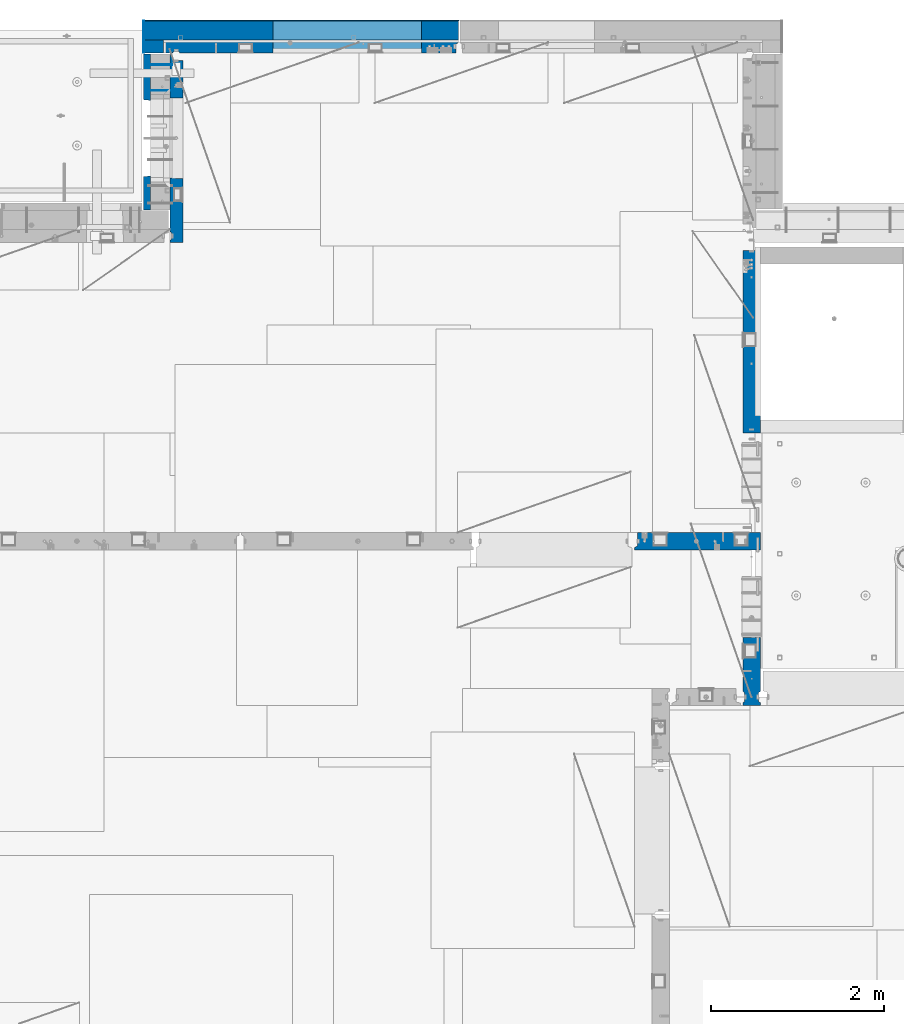
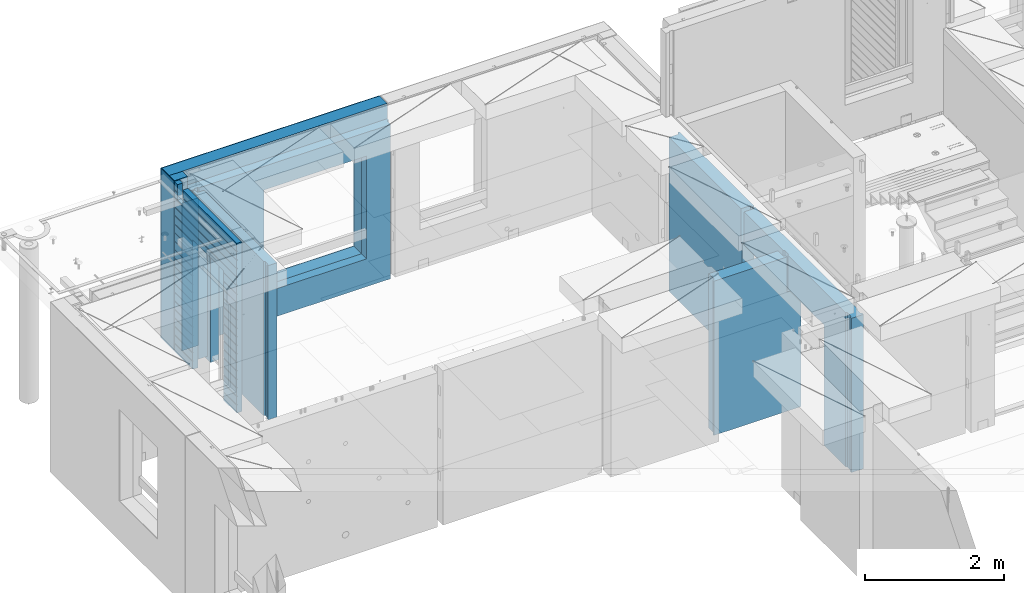
# One storey, part 236 of 349: 12 walls, 5 elements without a shape of their own.
"""IFC2X3 building model written with IfcOpenShell, lengths in millimetres."""

import ifcopenshell
import ifcopenshell.guid

model = None  # the IFC model being written
_history = None  # IfcOwnerHistory: only IFC2X3 demands one
_inside = {}  # id of a spatial element -> (the spatial element, [elements in it])
_under = {}  # id of a project, library or spatial element -> (it, [spatial elements below it])
_declared = {}  # id of a project -> (the project, [libraries it declares])
_typed = {}  # id of a type object -> (the type object, [elements of that type])
_made_of = {}  # id of a material, layer set ... -> (it, [elements and type objects made of it])


def new_model(schema):
    """Start an empty IFC model of exactly this schema.

    Asked for "IFC4X3", IfcOpenShell would pick the latest addendum, in which some entities
    have other attributes; the version numbers below select the first issue.
    IFC2X3 requires an IfcOwnerHistory on every rooted entity: one is made here for all.
    """
    global model, _history
    if schema == "IFC4X3":
        model = ifcopenshell.file(schema_version=(4, 3, 0, 0))
    else:
        model = ifcopenshell.file(schema=schema)
    _inside.clear()
    _under.clear()
    _declared.clear()
    _typed.clear()
    _made_of.clear()
    _history = None
    if model.schema == "IFC2X3":
        org = make("IfcOrganization", Name="unknown")
        user = make(
            "IfcPersonAndOrganization",
            ThePerson=make("IfcPerson", FamilyName="unknown"),
            TheOrganization=org,
        )
        app = make(
            "IfcApplication",
            ApplicationDeveloper=org,
            Version="unknown",
            ApplicationFullName="unknown",
            ApplicationIdentifier="unknown",
        )
        _history = make(
            "IfcOwnerHistory",
            OwningUser=user,
            OwningApplication=app,
            ChangeAction="ADDED",
            CreationDate=0,
        )
    return model


def make(cls, **values):
    """One entity of the class cls with the attributes given. An attribute that is None is left unset."""
    return model.create_entity(
        cls, **{name: value for name, value in values.items() if value is not None}
    )


def rooted(cls, **values):
    """An entity with a GlobalId (a new one), such as an element, a storey or a relation."""
    return make(cls, GlobalId=ifcopenshell.guid.new(), OwnerHistory=_history, **values)


def si_unit(unit_type, name, prefix=None):
    """IfcSIUnit, for example si_unit("LENGTHUNIT", "METRE", prefix="MILLI")."""
    return make("IfcSIUnit", UnitType=unit_type, Prefix=prefix, Name=name)


def assignment(units):
    """IfcUnitAssignment: the units of a project."""
    return None if units is None else make("IfcUnitAssignment", Units=units)


def point(xyz):
    """IfcCartesianPoint."""
    return None if xyz is None else make("IfcCartesianPoint", Coordinates=xyz)


def direction(xyz):
    """IfcDirection."""
    return None if xyz is None else make("IfcDirection", DirectionRatios=xyz)


def frame(location, z_axis=None, x_axis=None):
    """IfcAxis2Placement3D, a coordinate frame: its origin and axes. An axis left out is left unset."""
    return make(
        "IfcAxis2Placement3D",
        Location=point(location),
        Axis=direction(z_axis),
        RefDirection=direction(x_axis),
    )


def origin_with_axes():
    """The frame at (0, 0, 0) with the z axis (0, 0, 1) and the x axis (1, 0, 0) written out."""
    return frame((0.0, 0.0, 0.0), z_axis=(0.0, 0.0, 1.0), x_axis=(1.0, 0.0, 0.0))


def place(relative_to, where):
    """IfcLocalPlacement: puts the frame where relative to a parent placement (None: the world)."""
    return make(
        "IfcLocalPlacement", PlacementRelTo=relative_to, RelativePlacement=where
    )


def context(
    kind, dimensions, precision=None, world=None, true_north=None, identifier=None
):
    """IfcGeometricRepresentationContext, for example the 3D "Model" context."""
    return make(
        "IfcGeometricRepresentationContext",
        ContextIdentifier=identifier,
        ContextType=kind,
        CoordinateSpaceDimension=dimensions,
        Precision=precision,
        WorldCoordinateSystem=world,
        TrueNorth=true_north,
    )


def subcontext(parent, identifier, kind, view, scale=None):
    """IfcGeometricRepresentationSubContext, for example "Body" below "Model"."""
    return make(
        "IfcGeometricRepresentationSubContext",
        ContextIdentifier=identifier,
        ContextType=kind,
        ParentContext=parent,
        TargetScale=scale,
        TargetView=view,
    )


def project(units=None, contexts=None):
    """IfcProject with its units and contexts."""
    return rooted(
        "IfcProject",
        Name="project",
        RepresentationContexts=contexts,
        UnitsInContext=assignment(units),
    )


def spatial(cls, under=None, at=None, **own):
    """A site, building, storey or space (cls), placed at a placement, below another one or the project."""
    s = rooted(cls, ObjectPlacement=at, **own)
    if under is not None:
        _under.setdefault(under.id(), (under, []))[1].append(s)
    return s


def faces_of(points, faces, orient=None, outer=None):
    """IfcFace entities. A face is a list of loops; a loop is a list of indices into points, from 0.

    orient and outer hold one flag for each loop. By default every Orientation is true, the
    first loop of a face is its IfcFaceOuterBound and the others are IfcFaceBound.
    """
    made = []
    for i, loops in enumerate(faces):
        bounds = []
        for j, loop in enumerate(loops):
            is_outer = j == 0 if outer is None else outer[i][j]
            bounds.append(
                make(
                    "IfcFaceOuterBound" if is_outer else "IfcFaceBound",
                    Bound=make("IfcPolyLoop", Polygon=[points[k] for k in loop]),
                    Orientation=True if orient is None else orient[i][j],
                )
            )
        made.append(make("IfcFace", Bounds=bounds))
    return made


def faceted_brep(points, faces, orient=None, outer=None, voids=None):
    """IfcFacetedBrep: a solid bounded by flat faces; with voids (closed shells), ...WithVoids."""
    shared = [point(p) for p in points]
    hull = make("IfcClosedShell", CfsFaces=faces_of(shared, faces, orient, outer))
    if voids is None:
        return make("IfcFacetedBrep", Outer=hull)
    return make(
        "IfcFacetedBrepWithVoids",
        Outer=hull,
        Voids=[
            make(cls, CfsFaces=faces_of(shared, fs, o, b)) for cls, fs, o, b in voids
        ],
    )


def shape(context_of_items, identifier, shape_type, items):
    """IfcShapeRepresentation: the items that make up one representation, for example the "Body"."""
    return make(
        "IfcShapeRepresentation",
        ContextOfItems=context_of_items,
        RepresentationIdentifier=identifier,
        RepresentationType=shape_type,
        Items=items,
    )


def material(Name=None, Category=None):
    """IfcMaterial."""
    return make("IfcMaterial", Name=Name, Category=Category)


def made_of(thing, what):
    """Note that an element or type object is made of a material, layer set ...; save() writes the relation."""
    if what is not None:
        _made_of.setdefault(what.id(), (what, []))[1].append(thing)
    return thing


def type_object(cls, material=None, **own):
    """A type object (cls), such as IfcWallType, which elements share."""
    return made_of(rooted(cls, **own), material)


def element(
    cls,
    number,
    at=None,
    inside=None,
    cuts=None,
    type_object=None,
    material=None,
    context=None,
    identifier="Body",
    shape_type=None,
    held_by="IfcProductDefinitionShape",
    body=None,
    shapes=None,
    **own,
):
    """One element of the class cls, such as IfcWall. Its Tag is "e" and its number.

    at: its placement. inside: the storey or other place that contains it. cuts: it is an
    opening in that element (IfcRelVoidsElement). A single representation is given by context,
    identifier, shape_type and body (its items); several are given by shapes. held_by: the class
    of the entity that holds the representations. save() writes the other relations.
    """
    e = rooted(cls, Tag="e%d" % number, ObjectPlacement=at, **own)
    if body is not None:
        shapes = [shape(context, identifier, shape_type, body)]
    if shapes is not None:
        e.Representation = make(held_by, Representations=shapes)
    if inside is not None:
        _inside.setdefault(inside.id(), (inside, []))[1].append(e)
    if cuts is not None:
        rooted(
            "IfcRelVoidsElement", RelatingBuildingElement=cuts, RelatedOpeningElement=e
        )
    if type_object is not None:
        _typed.setdefault(type_object.id(), (type_object, []))[1].append(e)
    return made_of(e, material)


def aggregate(whole, parts):
    """IfcRelAggregates: a whole, such as a stair, and the parts it consists of."""
    return rooted("IfcRelAggregates", RelatingObject=whole, RelatedObjects=parts)


def save(model, path):
    """Write the relations noted so far, then the file.

    IfcRelAggregates (storeys below a building ...), IfcRelContainedInSpatialStructure (elements
    in a storey), IfcRelDefinesByType, IfcRelAssociatesMaterial and IfcRelDeclares: one each for
    every whole, place, type object, material and project.
    """
    for whole, parts in _under.values():
        aggregate(whole, parts)
    for where, things in _inside.values():
        rooted(
            "IfcRelContainedInSpatialStructure",
            RelatedElements=things,
            RelatingStructure=where,
        )
    for kind, things in _typed.values():
        rooted("IfcRelDefinesByType", RelatedObjects=things, RelatingType=kind)
    for what, things in _made_of.values():
        rooted("IfcRelAssociatesMaterial", RelatedObjects=things, RelatingMaterial=what)
    for by, libraries in _declared.values():
        rooted("IfcRelDeclares", RelatingContext=by, RelatedDefinitions=libraries)
    model.write(path)


model = new_model("IFC2X3")

# Units and contexts
model_context = context("Model", 3, precision=1e-05, world=origin_with_axes())
body_context = subcontext(model_context, "Body", "Model", "MODEL_VIEW")
ifc_project = project(units=[si_unit("LENGTHUNIT", "METRE", prefix="MILLI"), si_unit("AREAUNIT", "SQUARE_METRE"), si_unit("VOLUMEUNIT", "CUBIC_METRE"), si_unit("MASSUNIT", "GRAM", prefix="KILO"), si_unit("TIMEUNIT", "SECOND"), si_unit("PLANEANGLEUNIT", "RADIAN"), si_unit("SOLIDANGLEUNIT", "STERADIAN"), si_unit("THERMODYNAMICTEMPERATUREUNIT", "DEGREE_CELSIUS"), si_unit("LUMINOUSINTENSITYUNIT", "LUMEN")], contexts=[model_context])

# Site, building, storey
site_placement = place(None, origin_with_axes())
site = spatial("IfcSite", under=ifc_project, at=site_placement, CompositionType="ELEMENT")
building_placement = place(site_placement, origin_with_axes())
building = spatial("IfcBuilding", under=site, at=building_placement, CompositionType="ELEMENT")
storey_placement = place(building_placement, origin_with_axes())
storey = spatial("IfcBuildingStorey", under=building, at=storey_placement, Name="4", CompositionType="ELEMENT", Elevation=0.0)

# Assembly, walls
assembly_1_placement = place(storey_placement, origin_with_axes())
assembly_1 = element("IfcElementAssembly", 1, at=assembly_1_placement, inside=storey, AssemblyPlace="NOTDEFINED", PredefinedType="REINFORCEMENT_UNIT")
ifc_material_1 = material(Name="Undefined")
wall_type_1 = type_object("IfcWallType", PredefinedType="NOTDEFINED")
wall_1_placement = place(assembly_1_placement, frame((11020.0, 22485.0002441406, 92115.0), z_axis=(0.0, 0.0, 1.0), x_axis=(-1.0, 3.00000001838171e-08, 0.0)))
wall_1 = element("IfcWall", 2, at=wall_1_placement, type_object=wall_type_1, material=ifc_material_1, Name="(PD)", context=body_context, shape_type="Brep", body=[
    faceted_brep([(0.0, 5.0, -1300.0), (0.0, 5.0, 1300.0), (280.0, 5.0, 1300.0), (280.0, 5.0, -1300.0), (0.0, -5.0, 1300.0), (280.0, -5.0, 1300.0), (0.0, -5.0, -1300.0), (280.0, -5.0, -1300.0)], [[[0, 1, 2, 3]], [[1, 4, 5, 2]], [[4, 6, 7, 5]], [[6, 0, 3, 7]], [[5, 7, 3, 2]], [[6, 4, 1, 0]]]),
])
wall_2_placement = place(assembly_1_placement, frame((11020.0, 22185.0002441406, 92115.0), z_axis=(0.0, 0.0, 1.0), x_axis=(-1.0, 3.00000001838171e-08, 0.0)))
wall_2 = element("IfcWall", 3, at=wall_2_placement, type_object=wall_type_1, material=ifc_material_1, Name="(PD)", context=body_context, shape_type="Brep", body=[
    faceted_brep([(0.0, 5.0, -1300.0), (0.0, 5.0, 1300.0), (280.0, 5.0, 1300.0), (280.0, 5.0, -1300.0), (0.0, -5.0, 1300.0), (280.0, -5.0, 1300.0), (0.0, -5.0, -1300.0), (280.0, -5.0, -1300.0)], [[[0, 1, 2, 3]], [[1, 4, 5, 2]], [[4, 6, 7, 5]], [[6, 0, 3, 7]], [[5, 7, 3, 2]], [[6, 4, 1, 0]]]),
])

# Assembly, wall
assembly_2_placement = place(storey_placement, origin_with_axes())
assembly_2 = element("IfcElementAssembly", 4, at=assembly_2_placement, inside=storey, AssemblyPlace="NOTDEFINED", PredefinedType="REINFORCEMENT_UNIT")
ifc_material_2 = material(Name="CONCRETE/C25/30")
wall_type_2 = type_object("IfcWallType", PredefinedType="NOTDEFINED")
wall_3_placement = place(assembly_2_placement, frame((17710.0, 18214.9992663657, 92112.5), z_axis=(0.0, 0.0, 1.0), x_axis=(0.0, 1.0, 0.0)))
wall_3 = element("IfcWall", 5, at=wall_3_placement, type_object=wall_type_2, material=ifc_material_2, context=body_context, shape_type="Brep", body=[
    faceted_brep([(2120.00073363433, -57.0000000000036, 1357.5), (2120.00073363433, -57.0000000000036, -1357.5), (2120.00073363433, 100.0, -1357.5), (2120.00073363433, 100.0, 1357.5), (2165.00073363433, -70.0000000000036, 1357.5), (2165.00073363433, -70.0000000000036, -1357.5), (45.0, 100.0, 1357.5), (45.0, 100.0, 762.5), (45.0, -57.0, 762.5), (45.0, -57.0, 1357.5), (15.0, -70.0, 762.5), (15.0, 100.0, 762.5), (15.0, -70.0, 1357.5), (15.0, 100.0, -1357.5), (15.0, -100.0, -1357.5), (15.0, -100.0, 1357.5), (2165.00073363433, -100.0, -1357.5), (2165.00073363433, -100.0, 1357.5)], [[[0, 1, 2, 3]], [[4, 5, 1, 0]], [[6, 7, 8, 9]], [[10, 8, 7, 11]], [[12, 9, 8, 10]], [[11, 13, 14, 15, 12, 10]], [[15, 14, 16, 17]], [[3, 6, 9, 12, 15, 17, 4, 0]], [[13, 11, 7, 6, 3, 2]], [[16, 14, 13, 2, 1, 5]], [[17, 16, 5, 4]]]),
])
aggregate(assembly_2, [wall_3])

assembly_3_placement = place(storey_placement, origin_with_axes())
assembly_3 = element("IfcElementAssembly", 6, at=assembly_3_placement, inside=storey, AssemblyPlace="NOTDEFINED", PredefinedType="REINFORCEMENT_UNIT")
wall_4_placement = place(assembly_3_placement, frame((17710.0, 15080.0, 92112.5), z_axis=(0.0, 0.0, 1.0), x_axis=(0.0, 1.0, 0.0)))
wall_4 = element("IfcWall", 7, at=wall_4_placement, type_object=wall_type_2, material=ifc_material_2, context=body_context, shape_type="Brep", body=[
    faceted_brep([(3089.99926636568, -57.0, 1357.5), (3089.99926636568, -57.0, 762.5), (3089.99926620436, 100.0, 762.5), (3089.99926636568, 100.0, 1357.5), (3119.99926636568, -70.0, 1357.5), (3119.99926636568, -69.9999995451544, 762.5), (1965.00000368528, 100.0, 1357.5), (1965.00000368528, 99.9999997455598, 762.5), (1951.9999991369, 80.0000000823711, 762.5), (1951.9999991369, 80.0000000823711, 1357.5), (1848.00000041054, 79.9999993903439, 762.5), (1848.00000041054, 79.9999993903439, 1357.5), (1835.0, 100.0, 762.5), (1835.0, 100.0, 1357.5), (790.003238525391, -100.0, -1357.5), (790.003238525391, 100.0, -1357.5), (790.003238525391, 100.0, 762.5), (790.003238525391, -100.0, 762.5), (164.999999999998, 100.0, -1357.5), (164.999999999996, 100.0, 1357.5), (47.9997742438973, -79.9991481948964, 1357.5), (47.9997742438991, -79.9991481948928, -1357.5), (152.000000457021, -79.9991466091124, -1357.5), (152.000000457019, -79.9991466091124, 1357.5), (34.9997701872417, -100.0, 1357.5), (34.9997701872435, -100.0, -1357.5), (0.0, -100.0, 1357.5), (0.0, -100.0, -1357.5), (0.0, 100.0, 1357.5), (0.0, 100.0, -1357.5), (35.0, 100.0, 1357.5), (35.0, 100.0, -1357.5), (48.0, 80.0, 1357.5), (48.0, 80.0, -1357.5), (152.0, 80.0, 1357.5), (152.0, 80.0, -1357.5), (165.0, -100.0, -1357.5), (164.999999999998, -99.9991455078125, 1357.5), (3119.99926636568, -100.0, 762.5), (3119.99926636568, -100.0, 1357.5)], [[[0, 1, 2, 3]], [[4, 5, 1, 0]], [[6, 7, 8, 9]], [[9, 8, 10, 11]], [[11, 10, 12, 13]], [[14, 15, 16, 17]], [[13, 12, 16, 15, 18, 19]], [[20, 21, 22, 23]], [[24, 25, 21, 20]], [[26, 27, 25, 24]], [[27, 26, 28, 29]], [[29, 28, 30, 31]], [[32, 33, 31, 30]], [[34, 35, 33, 32]], [[19, 18, 35, 34]], [[15, 14, 36, 22, 21, 25, 27, 29, 31, 33, 35, 18]], [[37, 23, 22, 36]], [[14, 17, 38, 39, 37, 36]], [[13, 19, 34, 32, 30, 28, 26, 24, 20, 23, 37, 39, 4, 0, 3, 6, 9, 11]], [[7, 6, 3, 2]], [[38, 17, 16, 12, 10, 8, 7, 2, 1, 5]], [[39, 38, 5, 4]]]),
])
aggregate(assembly_3, [wall_4])

assembly_4_placement = place(storey_placement, origin_with_axes())
assembly_4 = element("IfcElementAssembly", 8, at=assembly_4_placement, inside=storey, AssemblyPlace="NOTDEFINED", PredefinedType="REINFORCEMENT_UNIT")
wall_5_placement = place(assembly_4_placement, frame((16359.9991042544, 16980.0, 92112.5), z_axis=(0.0, 0.0, 1.0), x_axis=(1.0, 0.0, 0.0)))
wall_5 = element("IfcWall", 9, at=wall_5_placement, type_object=wall_type_2, material=ifc_material_2, context=body_context, shape_type="Brep", body=[
    faceted_brep([(1185.00089736511, 100.0, 1357.5), (1185.00089574558, -57.0, 1357.5), (1185.00089574558, -57.0, 742.5), (1185.00089736511, 99.9999999278843, 742.5), (1220.00089574558, -70.2708332915754, 1357.5), (1220.00089574558, -70.270833291579, 742.5), (1220.00089574558, 100.000001967095, 742.5), (0.0, -100.0, -1357.5), (0.0, -100.0, 1357.5), (0.0, -70.0000178764712, 1357.5), (0.0, -70.0000178764712, -1357.5), (30.0000412533973, -57.0, 1357.5), (30.0000412533973, -57.0, -1357.5), (30.0000000000009, 100.0, 1357.5), (30.0, 100.0, -1357.5), (1450.0, 100.0, -1357.5), (1450.0, -100.0, -1357.5), (1450.00089574558, 100.0, 742.5), (1450.0, -100.0, 742.5), (1220.00089574558, -100.0, 1357.5), (1220.00089574558, -100.0, 742.5), (1225.00089532057, 100.0, 742.5)], [[[0, 1, 2, 3]], [[4, 5, 2, 1]], [[6, 3, 2, 5]], [[7, 8, 9, 10]], [[11, 12, 10, 9]], [[13, 14, 12, 11]], [[15, 16, 7, 10, 12, 14]], [[16, 15, 17, 18]], [[19, 8, 7, 16, 18, 20]], [[17, 21, 6, 5, 20, 18]], [[19, 20, 5, 4]], [[0, 13, 11, 9, 8, 19, 4, 1]], [[21, 17, 15, 14, 13, 0, 3, 6]]]),
])
aggregate(assembly_4, [wall_5])

# Assembly, walls
assembly_5_placement = place(storey_placement, origin_with_axes())
assembly_5 = element("IfcElementAssembly", 10, at=assembly_5_placement, inside=storey, AssemblyPlace="NOTDEFINED", PredefinedType="REINFORCEMENT_UNIT")
ifc_material_3 = material()
wall_type_3 = type_object("IfcWallType", PredefinedType="NOTDEFINED")
wall_6_placement = place(assembly_5_placement, frame((10805.0, 22620.0, 92247.5), z_axis=(0.0, 0.0, 1.0), x_axis=(0.0, 1.0, 0.0)))
wall_6 = element("IfcWall", 11, at=wall_6_placement, type_object=wall_type_3, material=ifc_material_3, context=body_context, shape_type="Brep", body=[
    faceted_brep([(0.0, 110.0, -1492.5), (0.0, 110.0, 1492.5), (150.0, 110.0, 1492.5), (150.0, 110.0, -1492.5), (0.0, -110.0, 1492.5), (150.0, -110.0, 1492.5), (0.0, -110.0, -1492.5), (150.0, -110.0, -1492.5)], [[[0, 1, 2, 3]], [[1, 4, 5, 2]], [[4, 6, 7, 5]], [[6, 0, 3, 7]], [[5, 7, 3, 2]], [[6, 4, 1, 0]]]),
])
wall_7_placement = place(assembly_5_placement, frame((10915.0, 22880.0, 92247.5), z_axis=(0.0, 0.0, 1.0), x_axis=(1.0, 0.0, 0.0)))
wall_7 = element("IfcWall", 12, at=wall_7_placement, type_object=wall_type_3, material=ifc_material_3, context=body_context, shape_type="Brep", body=[
    faceted_brep([(-220.0, -110.0, -1492.5), (-220.0, 110.0, -1492.5), (3410.0, 110.0, -1492.5), (3410.0, -110.0, -1492.5), (-220.0, -110.0, 1492.5), (-220.0, 110.0, 1492.5), (3410.0, -110.0, 1492.5), (3410.0, 110.0, 1492.5), (1270.00055091817, 110.0, -1002.5), (2980.00055091817, 110.0, -1002.5), (2980.00055091817, 110.0, 807.5), (1270.00055091817, 110.0, 807.5), (1270.00055091817, -110.0, -1002.5), (1270.00055091817, -110.0, 807.5), (2980.00055091817, -110.0, 807.5), (2980.00055091817, -110.0, -1002.5)], [[[0, 1, 2, 3]], [[0, 4, 5, 1]], [[5, 4, 6, 7]], [[1, 5, 7, 2], [8, 9, 10, 11]], [[6, 3, 2, 7]], [[4, 0, 3, 6], [12, 13, 14, 15]], [[10, 14, 13, 11]], [[9, 15, 14, 10]], [[8, 12, 15, 9]], [[11, 13, 12, 8]]]),
])

# Wall
ifc_material_4 = material(Name="CONCRETE/C30/37")
wall_type_4 = type_object("IfcWallType", PredefinedType="NOTDEFINED")
wall_8_placement = place(assembly_1_placement, frame((10727.5, 20805.0, 92247.5), z_axis=(0.0, 0.0, 1.0), x_axis=(0.0, 1.0, 0.0)))
wall_8 = element("IfcWall", 13, at=wall_8_placement, type_object=wall_type_4, material=ifc_material_4, context=body_context, shape_type="Brep", body=[
    faceted_brep([(1800.0, -42.5, 1492.5), (1800.0, 42.5, 1492.5), (1705.0, 42.5, 1492.5), (1705.0, -42.5, 1492.5), (0.0, 42.5, -1492.5), (0.0, 42.5, -1357.00000005524), (384.998212827581, 42.5, -1357.00000005524), (384.998212827581, 42.5, -1492.5), (0.0, 32.4999992507037, -1355.00000000074), (386.174879582417, 32.4999992506928, -1355.0000000008), (0.0, 32.4999991127006, -1344.99999959956), (386.174879598653, 32.4999991126915, -1344.99999959957), (0.0, 42.5, -1343.00000011075), (384.998212827581, 42.5, -1343.00000011075), (0.0, 42.5, -1207.00000005524), (384.998212827581, 42.5, -1207.00000005524), (0.0, 32.4999992507037, -1205.00000000074), (386.174879582417, 32.4999992506928, -1205.0000000008), (0.0, 32.4999991127006, -1194.99999959956), (386.174879598653, 32.4999991126915, -1194.99999959957), (0.0, 42.5, -1193.00000011075), (384.998212827581, 42.5, -1193.00000011075), (0.0, 42.5, -1057.00000005524), (384.998212827581, 42.5, -1057.00000005524), (0.0, 32.4999992507037, -1055.00000000074), (386.174879582417, 32.4999992506928, -1055.0000000008), (0.0, 32.4999991127006, -1044.99999959956), (386.174879598653, 32.4999991126915, -1044.99999959957), (0.0, 42.5, -1043.00000011075), (384.998212827581, 42.5, -1043.00000011075), (0.0, 42.5, -907.000000055239), (384.998212827581, 42.5, -907.000000055239), (0.0, 32.4999992507037, -905.000000000742), (386.174879582417, 32.4999992506928, -905.0000000008), (0.0, 32.4999991127006, -894.99999959956), (386.174879598653, 32.4999991126915, -894.999999599575), (0.0, 42.5, -893.000000110755), (384.998212827581, 42.5, -893.000000110755), (0.0, 42.5, -757.000000055239), (384.998212827581, 42.5, -757.000000055239), (0.0, 32.4999992507037, -755.000000000742), (386.174879582417, 32.4999992506928, -755.0000000008), (0.0, 32.4999991127006, -744.99999959956), (386.174879598653, 32.4999991126915, -744.999999599575), (0.0, 42.5, -743.000000110755), (384.998212827581, 42.5, -743.000000110755), (0.0, 42.5, -607.000000055239), (384.998212827581, 42.5, -607.000000055239), (3.63797880709171e-12, 32.4999992507037, -605.000000000742), (386.174879582417, 32.4999992506928, -605.0000000008), (3.63797880709171e-12, 32.4999991127006, -594.99999959956), (386.174879598653, 32.4999991126915, -594.999999599575), (0.0, 42.5, -593.000000110755), (384.998212827581, 42.5, -593.000000110755), (0.0, 42.5, -457.000000055239), (384.998212827581, 42.5, -457.000000055239), (0.0, 32.4999992507037, -455.000000000742), (386.174879582417, 32.4999992506928, -455.0000000008), (0.0, 32.4999991127006, -444.99999959956), (386.174879598653, 32.4999991126915, -444.999999599575), (0.0, 42.5, -443.000000110755), (384.998212827581, 42.5, -443.000000110755), (0.0, 42.5, -307.000000055239), (384.998212827581, 42.5, -307.000000055239), (0.0, 32.4999992507037, -305.000000000742), (386.174879582417, 32.4999992506928, -305.0000000008), (0.0, 32.4999991127006, -294.99999959956), (386.174879598653, 32.4999991126915, -294.999999599575), (0.0, 42.5, -293.000000110755), (384.998212827581, 42.5, -293.000000110755), (0.0, 42.5, -157.000000055239), (384.998212827581, 42.5, -157.000000055239), (3.63797880709171e-12, 32.4999992507037, -155.000000000742), (386.174879582417, 32.4999992506928, -155.0000000008), (3.63797880709171e-12, 32.4999991127006, -144.99999959956), (386.174879598653, 32.4999991126915, -144.999999599575), (0.0, 42.5, -143.000000110755), (384.998212827581, 42.5, -143.000000110755), (0.0, 42.5, -7.00000005523907), (384.998212827581, 42.5, -7.00000005523907), (0.0, 32.4999992507037, -5.00000000074215), (386.174879582417, 32.4999992506928, -5.00000000080036), (0.0, 32.4999991127006, 5.0000004004396), (386.174879598653, 32.4999991126915, 5.00000040042505), (0.0, 42.5, 6.99999988924537), (384.998212827581, 42.5, 6.99999988924537), (0.0, 42.5, 142.999999944761), (384.998212827581, 42.5, 142.999999944761), (-3.63797880709171e-12, 32.4999992507037, 144.999999999258), (386.174879582417, 32.4999992506928, 144.9999999992), (-3.63797880709171e-12, 32.4999991127006, 155.00000040044), (386.174879598653, 32.4999991126915, 155.000000400425), (0.0, 42.5, 156.999999889245), (384.998212827581, 42.5, 156.999999889245), (0.0, 42.5, 292.999999944761), (384.998212827581, 42.5, 292.999999944761), (-3.63797880709171e-12, 32.4999992507037, 294.999999999258), (386.174879582417, 32.4999992506928, 294.9999999992), (-3.63797880709171e-12, 32.4999991127006, 305.00000040044), (386.174879598653, 32.4999991126915, 305.000000400425), (0.0, 42.5, 306.999999889245), (384.998212827581, 42.5, 306.999999889245), (0.0, 42.5, 442.999999944761), (384.998212827581, 42.5, 442.999999944761), (0.0, 32.4999992507037, 444.999999999258), (386.174879582417, 32.4999992506928, 444.9999999992), (0.0, 32.4999991127006, 455.00000040044), (386.174879598653, 32.4999991126915, 455.000000400425), (0.0, 42.5, 456.999999889245), (384.998212827581, 42.5, 456.999999889245), (0.0, 42.5, 592.999999944761), (384.998212827581, 42.5, 592.999999944761), (3.63797880709171e-12, 32.4999992507037, 594.999999999258), (386.174879582417, 32.4999992506928, 594.9999999992), (3.63797880709171e-12, 32.4999991127006, 605.00000040044), (386.174879598653, 32.4999991126915, 605.000000400425), (0.0, 42.5, 606.999999889245), (384.998212827581, 42.5, 606.999999889245), (0.0, 42.5, 742.999999944761), (384.998212827581, 42.5, 742.999999944761), (0.0, 32.4999992507037, 744.999999999258), (386.174879582417, 32.4999992506928, 744.9999999992), (0.0, 32.4999991127006, 755.00000040044), (386.174879598653, 32.4999991126915, 755.000000400425), (0.0, 42.5, 756.999999889245), (384.998212827581, 42.5, 756.999999889245), (0.0, 42.5, 1206.99999988925), (1800.0, 42.5, 1206.99999988925), (1800.0, 32.4999991126897, 1205.00000040043), (0.0, 32.4999991127006, 1205.00000040044), (1800.0, 32.4999992507001, 1194.99999999923), (0.0, 32.4999992507037, 1194.99999999926), (0.0, 42.5, 1192.99999994476), (1800.0, 42.5, 1192.99999994476), (1800.0, 42.5, 1056.99999988925), (0.0, 42.5, 1056.99999988925), (1800.0, 32.4999991126897, 1055.00000040043), (0.0, 32.4999991127006, 1055.00000040044), (1800.0, 32.4999992507001, 1044.99999999923), (0.0, 32.4999992507037, 1044.99999999926), (0.0, 42.5, 1042.99999994476), (1800.0, 42.5, 1042.99999994476), (1800.0, 42.5, 906.999999889245), (0.0, 42.5, 906.999999889245), (1800.0, 32.4999991126897, 905.000000400425), (0.0, 32.4999991127006, 905.00000040044), (1800.0, 32.4999992507001, 894.999999999229), (0.0, 32.4999992507037, 894.999999999258), (0.0, 42.5, 892.999999944761), (1800.0, 42.5, 892.999999944761), (1800.0, 42.5, -1357.00000005524), (1800.0, 42.5, -1492.5), (1274.99821282758, 42.5, -1492.5), (1274.99821282758, 42.5, -1357.00000005524), (1800.0, 32.4999992507001, -1355.00000000077), (1273.82154607274, 32.4999992506928, -1355.0000000008), (1800.0, 32.4999991126897, -1344.99999959957), (1273.82154605651, 32.4999991126915, -1344.99999959957), (1800.0, 42.5, -1343.00000011075), (1274.99821282758, 42.5, -1343.00000011075), (1800.0, 42.5, -1207.00000005524), (1274.99821282758, 42.5, -1207.00000005524), (1800.0, 32.4999992507001, -1205.00000000077), (1273.82154607274, 32.4999992506928, -1205.0000000008), (1800.0, 32.4999991126897, -1194.99999959957), (1273.82154605651, 32.4999991126915, -1194.99999959957), (1800.0, 42.5, -1193.00000011075), (1274.99821282758, 42.5, -1193.00000011075), (1800.0, 42.5, -1057.00000005524), (1274.99821282758, 42.5, -1057.00000005524), (1800.0, 32.4999992507001, -1055.00000000077), (1273.82154607274, 32.4999992506928, -1055.0000000008), (1800.0, 32.4999991126897, -1044.99999959957), (1273.82154605651, 32.4999991126915, -1044.99999959957), (1800.0, 42.5, -1043.00000011075), (1274.99821282758, 42.5, -1043.00000011075), (1800.0, 42.5, -907.000000055239), (1274.99821282758, 42.5, -907.000000055239), (1800.0, 32.4999992507001, -905.000000000771), (1273.82154607274, 32.4999992506928, -905.0000000008), (1800.0, 32.4999991126897, -894.999999599575), (1273.82154605651, 32.4999991126915, -894.999999599575), (1800.0, 42.5, -893.000000110755), (1274.99821282758, 42.5, -893.000000110755), (1800.0, 42.5, -757.000000055239), (1274.99821282758, 42.5, -757.000000055239), (1800.0, 32.4999992507001, -755.000000000771), (1273.82154607274, 32.4999992506928, -755.0000000008), (1800.0, 32.4999991126897, -744.999999599575), (1273.82154605651, 32.4999991126915, -744.999999599575), (1800.0, 42.5, -743.000000110755), (1274.99821282758, 42.5, -743.000000110755), (1800.0, 42.5, -607.000000055239), (1274.99821282758, 42.5, -607.000000055239), (1800.0, 32.4999992507001, -605.000000000771), (1273.82154607274, 32.4999992506928, -605.0000000008), (1800.0, 32.4999991126897, -594.999999599575), (1273.82154605651, 32.4999991126915, -594.999999599575), (1800.0, 42.5, -593.000000110755), (1274.99821282758, 42.5, -593.000000110755), (1800.0, 42.5, -457.000000055239), (1274.99821282758, 42.5, -457.000000055239), (1800.0, 32.4999992507001, -455.000000000771), (1273.82154607274, 32.4999992506928, -455.0000000008), (1800.0, 32.4999991126897, -444.999999599575), (1273.82154605651, 32.4999991126915, -444.999999599575), (1800.0, 42.5, -443.000000110755), (1274.99821282758, 42.5, -443.000000110755), (1800.0, 42.5, -307.000000055239), (1274.99821282758, 42.5, -307.000000055239), (1800.0, 32.4999992507001, -305.000000000771), (1273.82154607274, 32.4999992506928, -305.0000000008), (1800.0, 32.4999991126897, -294.999999599575), (1273.82154605651, 32.4999991126915, -294.999999599575), (1800.0, 42.5, -293.000000110755), (1274.99821282758, 42.5, -293.000000110755), (1800.0, 42.5, -157.000000055239), (1274.99821282758, 42.5, -157.000000055239), (1800.0, 32.4999992507001, -155.000000000771), (1273.82154607274, 32.4999992506928, -155.0000000008), (1800.0, 32.4999991126897, -144.999999599575), (1273.82154605651, 32.4999991126915, -144.999999599575), (1800.0, 42.5, -143.000000110755), (1274.99821282758, 42.5, -143.000000110755), (1800.0, 42.5, -7.00000005523907), (1274.99821282758, 42.5, -7.00000005523907), (1800.0, 32.4999992507001, -5.00000000077125), (1273.82154607274, 32.4999992506928, -5.00000000080036), (1800.0, 32.4999991126897, 5.00000040042505), (1273.82154605651, 32.4999991126915, 5.00000040042505), (1800.0, 42.5, 6.99999988924537), (1274.99821282758, 42.5, 6.99999988924537), (1800.0, 42.5, 142.999999944761), (1274.99821282758, 42.5, 142.999999944761), (1800.0, 32.4999992507001, 144.999999999229), (1273.82154607274, 32.4999992506928, 144.9999999992), (1800.0, 32.4999991126897, 155.000000400425), (1273.82154605651, 32.4999991126915, 155.000000400425), (1800.0, 42.5, 156.999999889245), (1274.99821282758, 42.5, 156.999999889245), (1800.0, 42.5, 292.999999944761), (1274.99821282758, 42.5, 292.999999944761), (1800.0, 32.4999992507001, 294.999999999229), (1273.82154607274, 32.4999992506928, 294.9999999992), (1800.0, 32.4999991126897, 305.000000400425), (1273.82154605651, 32.4999991126915, 305.000000400425), (1800.0, 42.5, 306.999999889245), (1274.99821282758, 42.5, 306.999999889245), (1800.0, 42.5, 442.999999944761), (1274.99821282758, 42.5, 442.999999944761), (1800.0, 32.4999992507001, 444.999999999229), (1273.82154607274, 32.4999992506928, 444.9999999992), (1800.0, 32.4999991126897, 455.000000400425), (1273.82154605651, 32.4999991126915, 455.000000400425), (1800.0, 42.5, 456.999999889245), (1274.99821282758, 42.5, 456.999999889245), (1800.0, 42.5, 592.999999944761), (1274.99821282758, 42.5, 592.999999944761), (1800.0, 32.4999992507001, 594.999999999229), (1273.82154607274, 32.4999992506928, 594.9999999992), (1800.0, 32.4999991126897, 605.000000400425), (1273.82154605651, 32.4999991126915, 605.000000400425), (1800.0, 42.5, 606.999999889245), (1274.99821282758, 42.5, 606.999999889245), (1800.0, 42.5, 742.999999944761), (1274.99821282758, 42.5, 742.999999944761), (1800.0, 32.4999992507001, 744.999999999229), (1273.82154607274, 32.4999992506928, 744.9999999992), (1800.0, 32.4999991126897, 755.000000400425), (1273.82154605651, 32.4999991126915, 755.000000400425), (1800.0, 42.5, 756.999999889245), (1274.99821282758, 42.5, 756.999999889245), (395.000271651108, 42.5, 782.5), (384.998212827581, 42.5, 782.5), (1274.99821282758, 42.5, 782.5), (1265.00027165111, 42.5, 782.5), (394.999879494248, -42.5, 787.502857142856), (1264.99654616091, -42.5, 787.502857142856), (394.999879494248, -42.5, 782.5), (394.999879494248, -42.5, -1492.5), (0.0, -42.5, -1492.5), (-3.63797880709171e-12, 32.4999992507037, 1344.99999999926), (0.0, 42.5, 1342.99999994476), (0.0, -42.5, 1492.5), (0.0, 42.5, 1492.5), (0.0, 42.5, 1356.99999988925), (-3.63797880709171e-12, 32.4999991127006, 1355.00000040044), (1555.0, 42.5, 1356.99999988925), (1555.0, 32.4999991126915, 1355.00000040043), (1555.0, 32.4999992506928, 1344.9999999992), (1555.0, 42.5, 1342.99999994476), (1800.0, 42.5, 1342.99999994476), (1555.0, 42.5, 1222.5), (1705.0, 42.5, 1222.5), (1705.0, 42.5, 1343.0), (1800.0, 32.4999992507001, 1344.99999999923), (1705.0, 32.5, 1345.0), (1800.0, 32.4999991126897, 1355.00000040043), (1705.0, 32.5, 1355.0), (1800.0, 42.5, 1356.99999988925), (1705.0, 42.5, 1357.0), (1800.0, -42.5, -1492.5), (1264.99654616091, -42.5, -1492.5), (1264.99654616091, -42.5, 782.5), (1705.0, -42.5, 1222.5), (1555.0, -42.5, 1222.5), (1555.0, -42.5, 1492.5), (1555.0, 42.5, 1492.5)], [[[0, 1, 2, 3]], [[4, 5, 6, 7]], [[5, 8, 9, 6]], [[8, 10, 11, 9]], [[10, 12, 13, 11]], [[12, 14, 15, 13]], [[14, 16, 17, 15]], [[16, 18, 19, 17]], [[18, 20, 21, 19]], [[20, 22, 23, 21]], [[22, 24, 25, 23]], [[24, 26, 27, 25]], [[26, 28, 29, 27]], [[28, 30, 31, 29]], [[30, 32, 33, 31]], [[32, 34, 35, 33]], [[34, 36, 37, 35]], [[36, 38, 39, 37]], [[38, 40, 41, 39]], [[40, 42, 43, 41]], [[42, 44, 45, 43]], [[44, 46, 47, 45]], [[46, 48, 49, 47]], [[48, 50, 51, 49]], [[50, 52, 53, 51]], [[52, 54, 55, 53]], [[54, 56, 57, 55]], [[56, 58, 59, 57]], [[58, 60, 61, 59]], [[60, 62, 63, 61]], [[62, 64, 65, 63]], [[64, 66, 67, 65]], [[66, 68, 69, 67]], [[68, 70, 71, 69]], [[70, 72, 73, 71]], [[72, 74, 75, 73]], [[74, 76, 77, 75]], [[76, 78, 79, 77]], [[78, 80, 81, 79]], [[80, 82, 83, 81]], [[82, 84, 85, 83]], [[84, 86, 87, 85]], [[86, 88, 89, 87]], [[88, 90, 91, 89]], [[90, 92, 93, 91]], [[92, 94, 95, 93]], [[94, 96, 97, 95]], [[96, 98, 99, 97]], [[98, 100, 101, 99]], [[100, 102, 103, 101]], [[102, 104, 105, 103]], [[104, 106, 107, 105]], [[106, 108, 109, 107]], [[108, 110, 111, 109]], [[110, 112, 113, 111]], [[112, 114, 115, 113]], [[114, 116, 117, 115]], [[116, 118, 119, 117]], [[118, 120, 121, 119]], [[120, 122, 123, 121]], [[122, 124, 125, 123]], [[126, 127, 128, 129]], [[129, 128, 130, 131]], [[132, 131, 130, 133]], [[134, 135, 132, 133]], [[135, 134, 136, 137]], [[137, 136, 138, 139]], [[140, 139, 138, 141]], [[142, 143, 140, 141]], [[143, 142, 144, 145]], [[145, 144, 146, 147]], [[148, 147, 146, 149]], [[150, 151, 152, 153]], [[154, 150, 153, 155]], [[156, 154, 155, 157]], [[158, 156, 157, 159]], [[160, 158, 159, 161]], [[162, 160, 161, 163]], [[164, 162, 163, 165]], [[166, 164, 165, 167]], [[168, 166, 167, 169]], [[170, 168, 169, 171]], [[172, 170, 171, 173]], [[174, 172, 173, 175]], [[176, 174, 175, 177]], [[178, 176, 177, 179]], [[180, 178, 179, 181]], [[182, 180, 181, 183]], [[184, 182, 183, 185]], [[186, 184, 185, 187]], [[188, 186, 187, 189]], [[190, 188, 189, 191]], [[192, 190, 191, 193]], [[194, 192, 193, 195]], [[196, 194, 195, 197]], [[198, 196, 197, 199]], [[200, 198, 199, 201]], [[202, 200, 201, 203]], [[204, 202, 203, 205]], [[206, 204, 205, 207]], [[208, 206, 207, 209]], [[210, 208, 209, 211]], [[212, 210, 211, 213]], [[214, 212, 213, 215]], [[216, 214, 215, 217]], [[218, 216, 217, 219]], [[220, 218, 219, 221]], [[222, 220, 221, 223]], [[224, 222, 223, 225]], [[226, 224, 225, 227]], [[228, 226, 227, 229]], [[230, 228, 229, 231]], [[232, 230, 231, 233]], [[234, 232, 233, 235]], [[236, 234, 235, 237]], [[238, 236, 237, 239]], [[240, 238, 239, 241]], [[242, 240, 241, 243]], [[244, 242, 243, 245]], [[246, 244, 245, 247]], [[248, 246, 247, 249]], [[250, 248, 249, 251]], [[252, 250, 251, 253]], [[254, 252, 253, 255]], [[256, 254, 255, 257]], [[258, 256, 257, 259]], [[260, 258, 259, 261]], [[262, 260, 261, 263]], [[264, 262, 263, 265]], [[266, 264, 265, 267]], [[268, 266, 267, 269]], [[270, 268, 269, 271]], [[272, 273, 125, 124, 148, 149, 270, 271, 274, 275]], [[276, 273, 272, 275, 274, 277]], [[278, 279, 7, 6, 9, 11, 13, 15, 17, 19, 21, 23, 25, 27, 29, 31, 33, 35, 37, 39, 41, 43, 45, 47, 49, 51, 53, 55, 57, 59, 61, 63, 65, 67, 69, 71, 73, 75, 77, 79, 81, 83, 85, 87, 89, 91, 93, 95, 97, 99, 101, 103, 105, 107, 109, 111, 113, 115, 117, 119, 121, 123, 125, 273, 276]], [[280, 4, 7, 279]], [[281, 282, 126, 129, 131, 132, 135, 137, 139, 140, 143, 145, 147, 148, 124, 122, 120, 118, 116, 114, 112, 110, 108, 106, 104, 102, 100, 98, 96, 94, 92, 90, 88, 86, 84, 82, 80, 78, 76, 74, 72, 70, 68, 66, 64, 62, 60, 58, 56, 54, 52, 50, 48, 46, 44, 42, 40, 38, 36, 34, 32, 30, 28, 26, 24, 22, 20, 18, 16, 14, 12, 10, 8, 5, 4, 280, 283, 284, 285, 286]], [[286, 285, 287, 288]], [[281, 286, 288, 289]], [[282, 281, 289, 290]], [[291, 127, 126, 282, 290, 292, 293, 294]], [[295, 291, 294, 296]], [[297, 295, 296, 298]], [[299, 297, 298, 300]], [[1, 0, 301, 151, 150, 154, 156, 158, 160, 162, 164, 166, 168, 170, 172, 174, 176, 178, 180, 182, 184, 186, 188, 190, 192, 194, 196, 198, 200, 202, 204, 206, 208, 210, 212, 214, 216, 218, 220, 222, 224, 226, 228, 230, 232, 234, 236, 238, 240, 242, 244, 246, 248, 250, 252, 254, 256, 258, 260, 262, 264, 266, 268, 270, 149, 146, 144, 142, 141, 138, 136, 134, 133, 130, 128, 127, 291, 295, 297, 299]], [[151, 301, 302, 152]], [[303, 277, 274, 271, 269, 267, 265, 263, 261, 259, 257, 255, 253, 251, 249, 247, 245, 243, 241, 239, 237, 235, 233, 231, 229, 227, 225, 223, 221, 219, 217, 215, 213, 211, 209, 207, 205, 203, 201, 199, 197, 195, 193, 191, 189, 187, 185, 183, 181, 179, 177, 175, 173, 171, 169, 167, 165, 163, 161, 159, 157, 155, 153, 152, 302]], [[302, 301, 0, 3, 304, 305, 306, 283, 280, 279, 278, 276, 277, 303]], [[284, 283, 306, 307]], [[285, 284, 307, 287]], [[306, 305, 292, 290, 289, 288, 287, 307]], [[304, 293, 292, 305]], [[3, 2, 300, 298, 296, 294, 293, 304]], [[1, 299, 300, 2]]]),
])

wall_type_5 = type_object("IfcWallType", PredefinedType="NOTDEFINED")
wall_9_placement = place(assembly_1_placement, frame((11065.0, 20430.0, 92112.5), z_axis=(0.0, 0.0, 1.0), x_axis=(0.0, 1.0, 0.0)))
wall_9 = element("IfcWall", 14, at=wall_9_placement, type_object=wall_type_5, material=ifc_material_2, context=body_context, shape_type="Brep", body=[
    faceted_brep([(124.995187227563, 75.0, 1357.5), (124.995187227563, 75.0, -1357.5), (114.995187227563, 55.0, -1357.5), (114.995187227563, 55.0, 1357.5), (-0.00481277243670775, -75.0, -1357.5), (-0.00481277243670775, -75.0, 1357.5), (-0.00481277243670775, 75.0, 1357.5), (-0.00481277243670775, 75.0, -1357.5), (24.9951872275633, 75.0, 1357.5), (24.9951872275633, 75.0, -1357.5), (34.9951872275633, 55.0, 1357.5), (34.9951872275633, 55.0, -1357.5), (47.9951869124525, 54.9999994175378, 1357.5), (47.9951869124525, 54.9999994175378, -1357.5), (101.995186816988, 54.9999993903693, 1357.5), (101.995186816988, 54.9999993903693, -1357.5), (2105.0, -75.0, 1357.5), (2105.0, 32.0, 1357.5), (2175.0, 45.0, 1357.5), (2175.0, 75.0, 1357.5), (2105.0, -75.0, -1357.5), (2105.0, 32.0, -1357.5), (2175.0, 45.0, -1357.5), (2175.0, 75.0, -1357.5), (743.846425497264, 75.0, -1357.5), (1666.15411780495, 75.0, -1357.5), (1666.15411780496, 75.0, 948.653846153844), (743.846425497261, 75.0, 948.653846153844), (740.000271651108, -75.0, -1357.5), (740.000271651108, -75.0, 952.5), (1670.00027165111, -75.0, 952.5), (1670.00027165111, -75.0, -1357.5)], [[[0, 1, 2, 3]], [[4, 5, 6, 7]], [[7, 6, 8, 9]], [[10, 11, 9, 8]], [[12, 13, 11, 10]], [[14, 15, 13, 12]], [[3, 2, 15, 14]], [[12, 10, 8, 6, 5, 16, 17, 18, 19, 0, 3, 14]], [[16, 20, 21, 17]], [[17, 21, 22, 18]], [[23, 19, 18, 22]], [[24, 1, 0, 19, 23, 25, 26, 27]], [[4, 7, 9, 11, 13, 15, 2, 1, 24, 28]], [[20, 16, 5, 4, 28, 29, 30, 31]], [[23, 22, 21, 20, 31, 25]], [[30, 26, 25, 31]], [[29, 27, 26, 30]], [[28, 24, 27, 29]]]),
])

aggregate(assembly_1, [wall_1, wall_2, wall_8, wall_9])

wall_10_placement = place(assembly_5_placement, frame((11142.5, 22695.0, 92112.5), z_axis=(0.0, 0.0, 1.0), x_axis=(1.0, 0.0, 0.0)))
wall_10 = element("IfcWall", 15, at=wall_10_placement, type_object=wall_type_5, material=ifc_material_2, context=body_context, shape_type="Brep", body=[
    faceted_brep([(1042.50055091817, 75.0, 942.5), (1042.50055091817, -75.0000013522877, 942.5), (1042.50055091817, -75.0000005925758, -867.5), (1042.50055091817, 75.0, -867.5), (2752.50055091817, -75.0000003030254, -867.5), (2752.50055091817, 75.0, -867.5), (2752.50055091817, -75.0000010627373, 942.5), (2752.50055091817, 75.0, 942.5), (-227.5, 75.0, -1357.5), (-227.5, 75.0, 1357.5), (3182.5, 75.0, 1357.5), (3182.5, 75.0, -1357.5), (-227.5, -75.0, -1357.5), (-227.5, -75.0, 1357.5), (-117.5, -75.0, -1357.5), (-117.5, -75.0, 1357.5), (-104.499999589396, -54.9999993903875, -1357.5), (-104.499999589396, -54.9999993903875, 1357.5), (-50.4999996848892, -54.9999994175341, -1357.5), (-50.4999996848892, -54.9999994175341, 1357.5), (-37.4999972154728, -75.0000022791319, 1357.5), (-37.4999972154728, -75.0, -1357.5), (3152.5, -75.0000000212349, 1357.5), (3152.5, 24.9999980926514, 1357.5), (3182.5, 45.0, 1357.5), (3182.5, 45.0, -1357.5), (3152.5, -75.0, -1357.5), (3152.5, 24.9999980926514, -1357.5)], [[[0, 1, 2, 3]], [[3, 2, 4, 5]], [[5, 4, 6, 7]], [[7, 6, 1, 0]], [[8, 9, 10, 11], [3, 5, 7, 0]], [[12, 13, 9, 8]], [[13, 12, 14, 15]], [[15, 14, 16, 17]], [[17, 16, 18, 19]], [[20, 19, 18, 21]], [[10, 9, 13, 15, 17, 19, 20, 22, 23, 24]], [[11, 10, 24, 25]], [[26, 21, 18, 16, 14, 12, 8, 11, 25, 27]], [[24, 23, 27, 25]], [[22, 26, 27, 23]], [[20, 21, 26, 22], [2, 1, 6, 4]]]),
])

wall_type_6 = type_object("IfcWallType", PredefinedType="NOTDEFINED")
wall_11_placement = place(assembly_5_placement, frame((10690.0, 22620.0, 92247.5), z_axis=(0.0, 0.0, 1.0), x_axis=(0.0, 1.0, 0.0)))
wall_11 = element("IfcWall", 16, at=wall_11_placement, type_object=wall_type_6, material=ifc_material_4, context=body_context, shape_type="Brep", body=[
    faceted_brep([(0.0, 5.0, -1492.5), (0.0, 5.0, 1492.5), (370.0, 5.0, 1492.5), (370.0, 5.0, -1492.5), (0.0, -5.0, 1492.5), (370.0, -5.0, 1492.5), (0.0, -5.0, -1492.5), (370.0, -5.0, -1492.5)], [[[0, 1, 2, 3]], [[1, 4, 5, 2]], [[4, 6, 7, 5]], [[6, 0, 3, 7]], [[5, 7, 3, 2]], [[6, 4, 1, 0]]]),
])

wall_12_placement = place(assembly_5_placement, frame((10915.0, 22995.0, 92247.5), z_axis=(0.0, 0.0, 1.0), x_axis=(1.0, 0.0, 0.0)))
wall_12 = element("IfcWall", 17, at=wall_12_placement, type_object=wall_type_6, material=ifc_material_4, context=body_context, shape_type="Brep", body=[
    faceted_brep([(-230.0, -5.0, -1492.5), (-230.0, 5.0, -1492.5), (3410.0, 5.0, -1492.5), (3410.0, -5.0, -1492.5), (-230.0, -5.0, 1492.5), (-230.0, 5.0, 1492.5), (3410.0, -5.0, 1492.5), (3410.0, 5.0, 1492.5), (1270.00055091817, 5.0, -1002.5), (2980.00055091817, 5.0, -1002.5), (2980.00055091817, 5.0, 807.5), (1270.00055091817, 5.0, 807.5), (1270.00055091817, -5.0, -1002.5), (1270.00055091817, -5.0, 807.5), (2980.00055091817, -5.0, 807.5), (2980.00055091817, -5.0, -1002.5)], [[[0, 1, 2, 3]], [[0, 4, 5, 1]], [[5, 4, 6, 7]], [[1, 5, 7, 2], [8, 9, 10, 11]], [[6, 3, 2, 7]], [[4, 0, 3, 6], [12, 13, 14, 15]], [[10, 14, 13, 11]], [[9, 15, 14, 10]], [[8, 12, 15, 9]], [[11, 13, 12, 8]]]),
])

aggregate(assembly_5, [wall_11, wall_6, wall_7, wall_12, wall_10])

save(model, "model.ifc")
